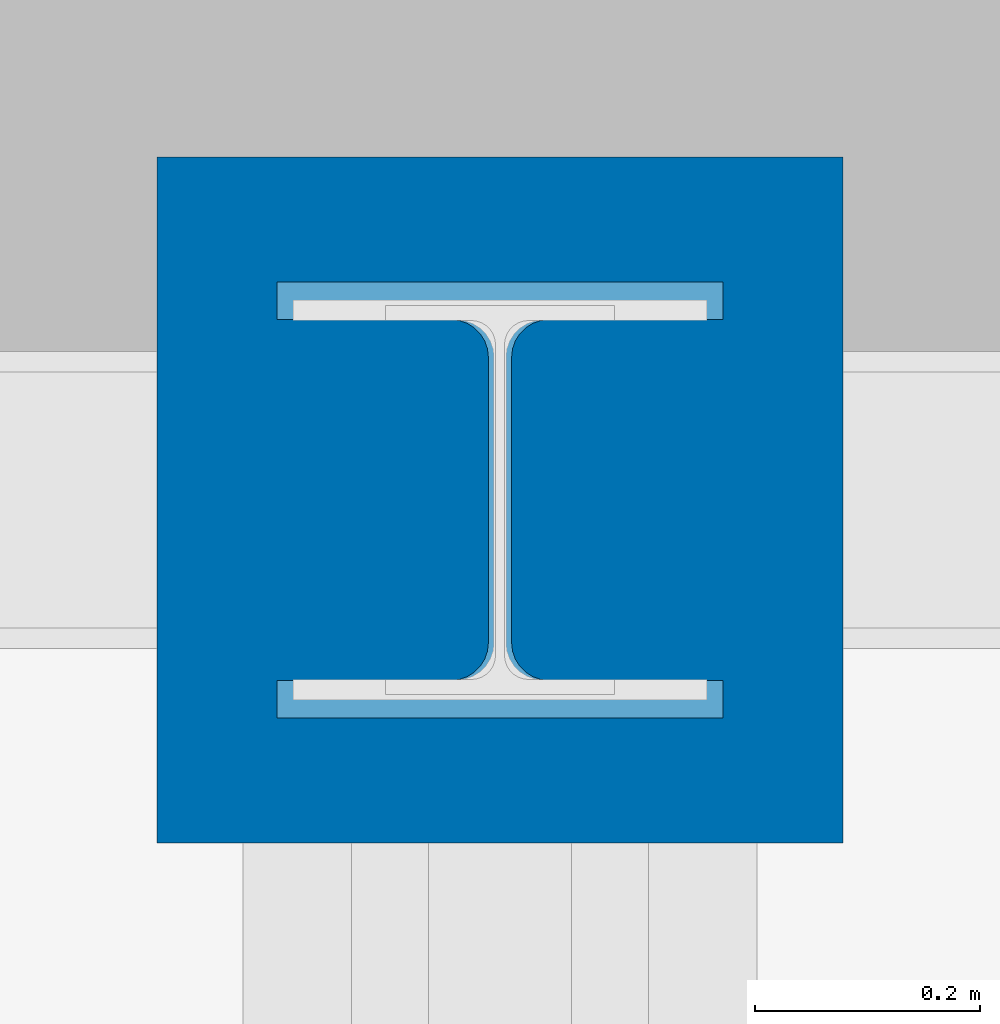
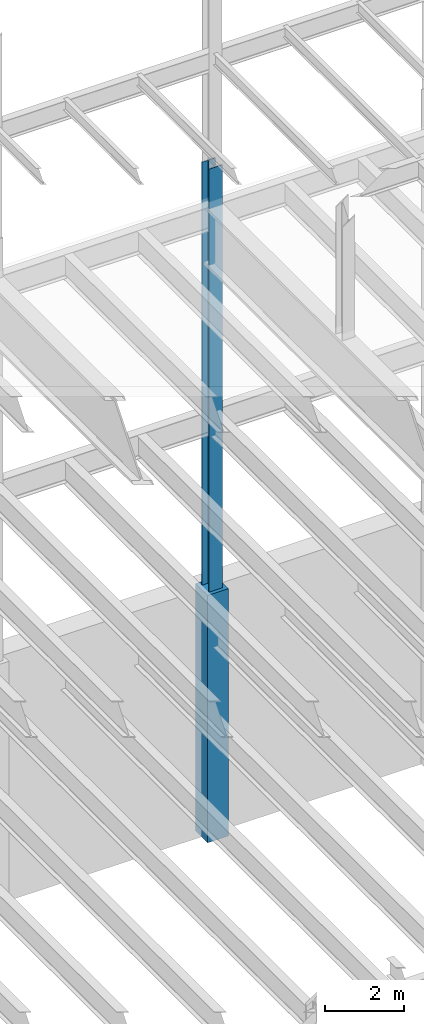
# One storey, part 63 of 150: 2 columns.
"""IFC2X3 building model written with IfcOpenShell, lengths in millimetres."""

from ifc_helpers import new_model, si_unit, frame, origin_with_axes, origin_2d_with_axis, place, context, subcontext, project, spatial, rectangle, i_section, extrude, material, type_object, element, save


model = new_model("IFC2X3")

# Units and contexts
model_context = context("Model", 3, precision=1e-05, world=origin_with_axes())
body_context = subcontext(model_context, "Body", "Model", "MODEL_VIEW")
ifc_project = project(units=[si_unit("LENGTHUNIT", "METRE", prefix="MILLI"), si_unit("AREAUNIT", "SQUARE_METRE"), si_unit("VOLUMEUNIT", "CUBIC_METRE"), si_unit("MASSUNIT", "GRAM", prefix="KILO"), si_unit("TIMEUNIT", "SECOND"), si_unit("PLANEANGLEUNIT", "RADIAN"), si_unit("SOLIDANGLEUNIT", "STERADIAN"), si_unit("THERMODYNAMICTEMPERATUREUNIT", "DEGREE_CELSIUS"), si_unit("LUMINOUSINTENSITYUNIT", "LUMEN")], contexts=[model_context])

# Site, building, storey
site_placement = place(None, origin_with_axes())
site = spatial("IfcSite", under=ifc_project, at=site_placement, CompositionType="ELEMENT")
building_placement = place(site_placement, origin_with_axes())
building = spatial("IfcBuilding", under=site, at=building_placement, Name="Undefined", CompositionType="ELEMENT")
storey_placement = place(building_placement, origin_with_axes())
storey = spatial("IfcBuildingStorey", under=building, at=storey_placement, Name="Undefined", CompositionType="ELEMENT", Elevation=0.0)

# Columns
ifc_material_1 = material(Name="STEEL/A992")
column_type_1 = type_object("IfcColumnType", Name="W14X176", PredefinedType="NOTDEFINED")
column_1_placement = place(storey_placement, frame((30988.0, 38862.0, 22707.6), z_axis=(0.0, 0.0, 1.0), x_axis=(1.0, 0.0, 0.0)))
element("IfcColumn", 1, at=column_1_placement, inside=storey, type_object=column_type_1, material=ifc_material_1, Name="COLUMN", ObjectType="W14X176", context=body_context, shape_type="SweptSolid", body=[
    extrude(i_section(OverallWidth=396.875, OverallDepth=387.35, WebThickness=20.6375, FlangeThickness=33.274, FilletRadius=33.401, at=origin_2d_with_axis()), frame((0.0, 0.0, 14097.0012877801), z_axis=(0.0, 0.0, -1.0), x_axis=(-1.0, 0.0, 0.0)), (0.0, 0.0, 1.0), 14097.0012877801),
])
ifc_material_2 = material(Name="CONCRETE/5000")
column_type_2 = type_object("IfcColumnType", PredefinedType="NOTDEFINED")
column_2_placement = place(storey_placement, frame((30988.0, 38862.0, 16154.4), z_axis=(0.0, 0.0, 1.0), x_axis=(1.0, 0.0, 0.0)))
element("IfcColumn", 2, at=column_2_placement, inside=storey, type_object=column_type_2, material=ifc_material_2, Name="COLUMN", context=body_context, shape_type="SweptSolid", body=[
    extrude(rectangle(XDim=609.6, YDim=609.6, at=origin_2d_with_axis()), frame((0.0, 0.0, 7620.0), z_axis=(0.0, 0.0, -1.0), x_axis=(0.0, -1.0, 0.0)), (0.0, 0.0, 1.0), 7620.0),
])

save(model, "model.ifc")
